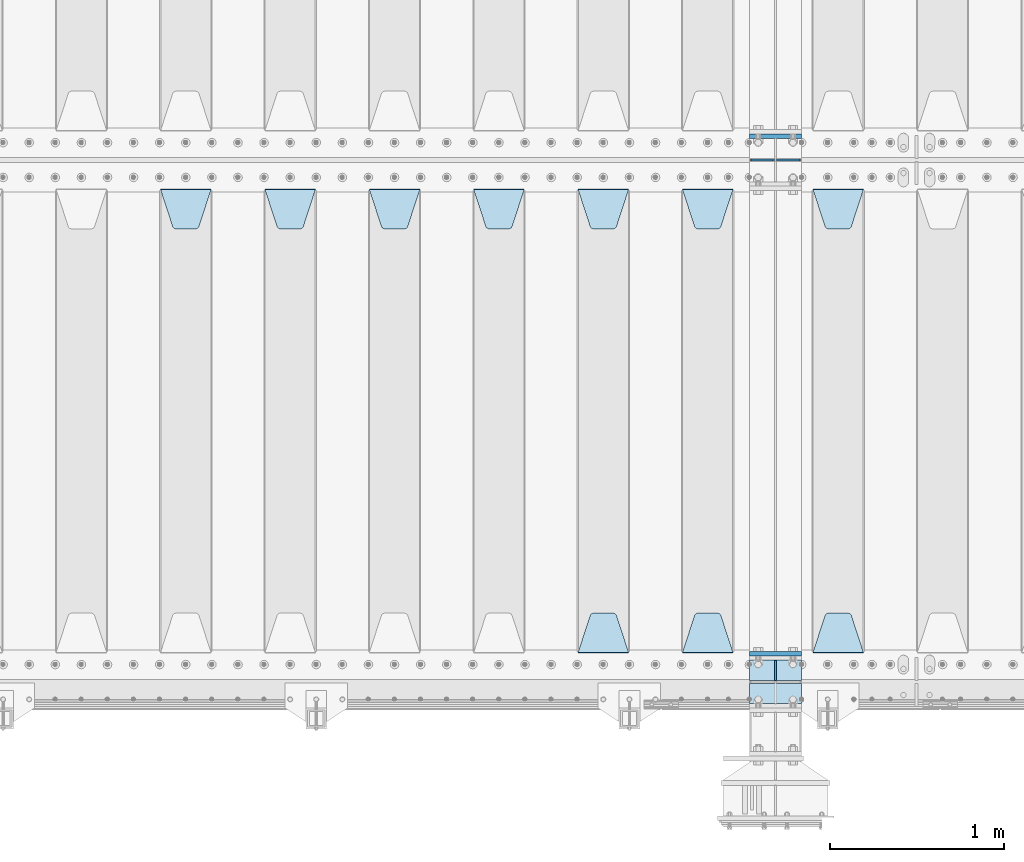
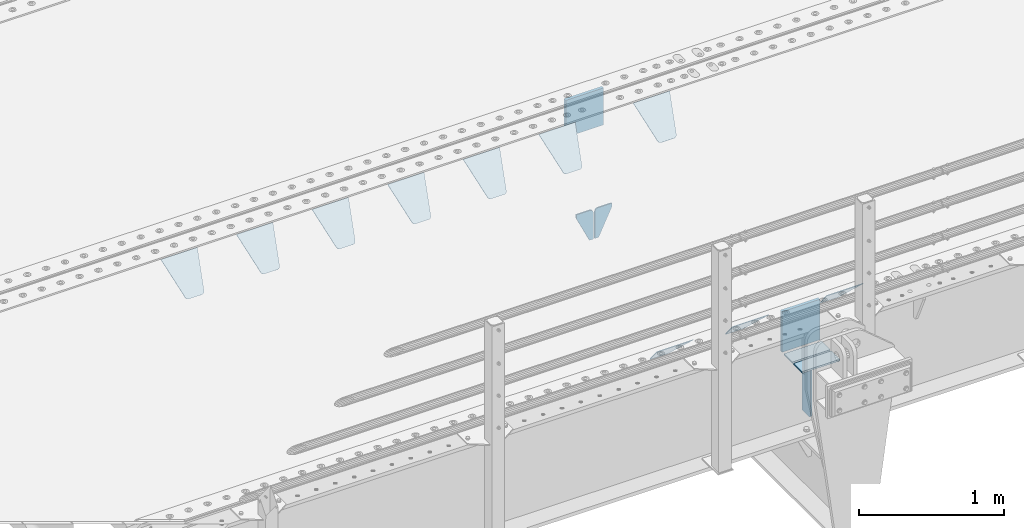
# One storey, part 183 of 219: 17 plates.
"""IFC2X3 building model written with IfcOpenShell, lengths in millimetres."""

import ifcopenshell
import ifcopenshell.guid

model = None  # the IFC model being written
_history = None  # IfcOwnerHistory: only IFC2X3 demands one
_inside = {}  # id of a spatial element -> (the spatial element, [elements in it])
_under = {}  # id of a project, library or spatial element -> (it, [spatial elements below it])
_declared = {}  # id of a project -> (the project, [libraries it declares])
_typed = {}  # id of a type object -> (the type object, [elements of that type])
_made_of = {}  # id of a material, layer set ... -> (it, [elements and type objects made of it])


def new_model(schema):
    """Start an empty IFC model of exactly this schema.

    Asked for "IFC4X3", IfcOpenShell would pick the latest addendum, in which some entities
    have other attributes; the version numbers below select the first issue.
    IFC2X3 requires an IfcOwnerHistory on every rooted entity: one is made here for all.
    """
    global model, _history
    if schema == "IFC4X3":
        model = ifcopenshell.file(schema_version=(4, 3, 0, 0))
    else:
        model = ifcopenshell.file(schema=schema)
    _inside.clear()
    _under.clear()
    _declared.clear()
    _typed.clear()
    _made_of.clear()
    _history = None
    if model.schema == "IFC2X3":
        org = make("IfcOrganization", Name="unknown")
        user = make(
            "IfcPersonAndOrganization",
            ThePerson=make("IfcPerson", FamilyName="unknown"),
            TheOrganization=org,
        )
        app = make(
            "IfcApplication",
            ApplicationDeveloper=org,
            Version="unknown",
            ApplicationFullName="unknown",
            ApplicationIdentifier="unknown",
        )
        _history = make(
            "IfcOwnerHistory",
            OwningUser=user,
            OwningApplication=app,
            ChangeAction="ADDED",
            CreationDate=0,
        )
    return model


def make(cls, **values):
    """One entity of the class cls with the attributes given. An attribute that is None is left unset."""
    return model.create_entity(
        cls, **{name: value for name, value in values.items() if value is not None}
    )


def rooted(cls, **values):
    """An entity with a GlobalId (a new one), such as an element, a storey or a relation."""
    return make(cls, GlobalId=ifcopenshell.guid.new(), OwnerHistory=_history, **values)


def si_unit(unit_type, name, prefix=None):
    """IfcSIUnit, for example si_unit("LENGTHUNIT", "METRE", prefix="MILLI")."""
    return make("IfcSIUnit", UnitType=unit_type, Prefix=prefix, Name=name)


def assignment(units):
    """IfcUnitAssignment: the units of a project."""
    return None if units is None else make("IfcUnitAssignment", Units=units)


def point(xyz):
    """IfcCartesianPoint."""
    return None if xyz is None else make("IfcCartesianPoint", Coordinates=xyz)


def direction(xyz):
    """IfcDirection."""
    return None if xyz is None else make("IfcDirection", DirectionRatios=xyz)


def frame(location, z_axis=None, x_axis=None):
    """IfcAxis2Placement3D, a coordinate frame: its origin and axes. An axis left out is left unset."""
    return make(
        "IfcAxis2Placement3D",
        Location=point(location),
        Axis=direction(z_axis),
        RefDirection=direction(x_axis),
    )


def origin_with_axes():
    """The frame at (0, 0, 0) with the z axis (0, 0, 1) and the x axis (1, 0, 0) written out."""
    return frame((0.0, 0.0, 0.0), z_axis=(0.0, 0.0, 1.0), x_axis=(1.0, 0.0, 0.0))


def place(relative_to, where):
    """IfcLocalPlacement: puts the frame where relative to a parent placement (None: the world)."""
    return make(
        "IfcLocalPlacement", PlacementRelTo=relative_to, RelativePlacement=where
    )


def context(
    kind, dimensions, precision=None, world=None, true_north=None, identifier=None
):
    """IfcGeometricRepresentationContext, for example the 3D "Model" context."""
    return make(
        "IfcGeometricRepresentationContext",
        ContextIdentifier=identifier,
        ContextType=kind,
        CoordinateSpaceDimension=dimensions,
        Precision=precision,
        WorldCoordinateSystem=world,
        TrueNorth=true_north,
    )


def subcontext(parent, identifier, kind, view, scale=None):
    """IfcGeometricRepresentationSubContext, for example "Body" below "Model"."""
    return make(
        "IfcGeometricRepresentationSubContext",
        ContextIdentifier=identifier,
        ContextType=kind,
        ParentContext=parent,
        TargetScale=scale,
        TargetView=view,
    )


def project(units=None, contexts=None):
    """IfcProject with its units and contexts."""
    return rooted(
        "IfcProject",
        Name="project",
        RepresentationContexts=contexts,
        UnitsInContext=assignment(units),
    )


def spatial(cls, under=None, at=None, **own):
    """A site, building, storey or space (cls), placed at a placement, below another one or the project."""
    s = rooted(cls, ObjectPlacement=at, **own)
    if under is not None:
        _under.setdefault(under.id(), (under, []))[1].append(s)
    return s


def faces_of(points, faces, orient=None, outer=None):
    """IfcFace entities. A face is a list of loops; a loop is a list of indices into points, from 0.

    orient and outer hold one flag for each loop. By default every Orientation is true, the
    first loop of a face is its IfcFaceOuterBound and the others are IfcFaceBound.
    """
    made = []
    for i, loops in enumerate(faces):
        bounds = []
        for j, loop in enumerate(loops):
            is_outer = j == 0 if outer is None else outer[i][j]
            bounds.append(
                make(
                    "IfcFaceOuterBound" if is_outer else "IfcFaceBound",
                    Bound=make("IfcPolyLoop", Polygon=[points[k] for k in loop]),
                    Orientation=True if orient is None else orient[i][j],
                )
            )
        made.append(make("IfcFace", Bounds=bounds))
    return made


def faceted_brep(points, faces, orient=None, outer=None, voids=None):
    """IfcFacetedBrep: a solid bounded by flat faces; with voids (closed shells), ...WithVoids."""
    shared = [point(p) for p in points]
    hull = make("IfcClosedShell", CfsFaces=faces_of(shared, faces, orient, outer))
    if voids is None:
        return make("IfcFacetedBrep", Outer=hull)
    return make(
        "IfcFacetedBrepWithVoids",
        Outer=hull,
        Voids=[
            make(cls, CfsFaces=faces_of(shared, fs, o, b)) for cls, fs, o, b in voids
        ],
    )


def shape(context_of_items, identifier, shape_type, items):
    """IfcShapeRepresentation: the items that make up one representation, for example the "Body"."""
    return make(
        "IfcShapeRepresentation",
        ContextOfItems=context_of_items,
        RepresentationIdentifier=identifier,
        RepresentationType=shape_type,
        Items=items,
    )


def material(Name=None, Category=None):
    """IfcMaterial."""
    return make("IfcMaterial", Name=Name, Category=Category)


def made_of(thing, what):
    """Note that an element or type object is made of a material, layer set ...; save() writes the relation."""
    if what is not None:
        _made_of.setdefault(what.id(), (what, []))[1].append(thing)
    return thing


def type_object(cls, material=None, **own):
    """A type object (cls), such as IfcWallType, which elements share."""
    return made_of(rooted(cls, **own), material)


def element(
    cls,
    number,
    at=None,
    inside=None,
    cuts=None,
    type_object=None,
    material=None,
    context=None,
    identifier="Body",
    shape_type=None,
    held_by="IfcProductDefinitionShape",
    body=None,
    shapes=None,
    **own,
):
    """One element of the class cls, such as IfcWall. Its Tag is "e" and its number.

    at: its placement. inside: the storey or other place that contains it. cuts: it is an
    opening in that element (IfcRelVoidsElement). A single representation is given by context,
    identifier, shape_type and body (its items); several are given by shapes. held_by: the class
    of the entity that holds the representations. save() writes the other relations.
    """
    e = rooted(cls, Tag="e%d" % number, ObjectPlacement=at, **own)
    if body is not None:
        shapes = [shape(context, identifier, shape_type, body)]
    if shapes is not None:
        e.Representation = make(held_by, Representations=shapes)
    if inside is not None:
        _inside.setdefault(inside.id(), (inside, []))[1].append(e)
    if cuts is not None:
        rooted(
            "IfcRelVoidsElement", RelatingBuildingElement=cuts, RelatedOpeningElement=e
        )
    if type_object is not None:
        _typed.setdefault(type_object.id(), (type_object, []))[1].append(e)
    return made_of(e, material)


def aggregate(whole, parts):
    """IfcRelAggregates: a whole, such as a stair, and the parts it consists of."""
    return rooted("IfcRelAggregates", RelatingObject=whole, RelatedObjects=parts)


def save(model, path):
    """Write the relations noted so far, then the file.

    IfcRelAggregates (storeys below a building ...), IfcRelContainedInSpatialStructure (elements
    in a storey), IfcRelDefinesByType, IfcRelAssociatesMaterial and IfcRelDeclares: one each for
    every whole, place, type object, material and project.
    """
    for whole, parts in _under.values():
        aggregate(whole, parts)
    for where, things in _inside.values():
        rooted(
            "IfcRelContainedInSpatialStructure",
            RelatedElements=things,
            RelatingStructure=where,
        )
    for kind, things in _typed.values():
        rooted("IfcRelDefinesByType", RelatedObjects=things, RelatingType=kind)
    for what, things in _made_of.values():
        rooted("IfcRelAssociatesMaterial", RelatedObjects=things, RelatingMaterial=what)
    for by, libraries in _declared.values():
        rooted("IfcRelDeclares", RelatingContext=by, RelatedDefinitions=libraries)
    model.write(path)


model = new_model("IFC2X3")

# Units and contexts
model_context = context("Model", 3, precision=1e-05, world=origin_with_axes())
body_context = subcontext(model_context, "Body", "Model", "MODEL_VIEW")
ifc_project = project(units=[si_unit("LENGTHUNIT", "METRE", prefix="MILLI"), si_unit("AREAUNIT", "SQUARE_METRE"), si_unit("VOLUMEUNIT", "CUBIC_METRE"), si_unit("MASSUNIT", "GRAM", prefix="KILO"), si_unit("TIMEUNIT", "SECOND"), si_unit("PLANEANGLEUNIT", "RADIAN"), si_unit("SOLIDANGLEUNIT", "STERADIAN"), si_unit("THERMODYNAMICTEMPERATUREUNIT", "DEGREE_CELSIUS"), si_unit("LUMINOUSINTENSITYUNIT", "LUMEN")], contexts=[model_context])

# Site, building, storey
site_placement = place(None, origin_with_axes())
site = spatial("IfcSite", under=ifc_project, at=site_placement, CompositionType="ELEMENT")
building_placement = place(site_placement, origin_with_axes())
building = spatial("IfcBuilding", under=site, at=building_placement, Name="Standard", CompositionType="ELEMENT")
storey_placement = place(building_placement, origin_with_axes())
storey = spatial("IfcBuildingStorey", under=building, at=storey_placement, Name="Undefined", CompositionType="ELEMENT", Elevation=0.0)

# Plates
ifc_material = material(Name="STEEL/S355N")
plate_type_1 = type_object("IfcPlateType", PredefinedType="NOTDEFINED")
plate_1_placement = place(storey_placement, frame((10240.0, 27137.5, -340.0), z_axis=(0.0, 0.0, 1.0), x_axis=(1.0, 0.0, 0.0)))
element("IfcPlate", 1, at=plate_1_placement, inside=storey, type_object=plate_type_1, material=ifc_material, context=body_context, shape_type="Brep", body=[
    faceted_brep([(0.0, -12.5, 0.0), (0.0, -12.5, 310.0), (0.0, 12.5, 310.0), (0.0, 12.5, 0.0), (300.0, -12.5, 310.0), (300.0, 12.5, 310.0), (300.0, -12.5, 0.0), (300.0, 12.5, 0.0)], [[[0, 1, 2, 3]], [[1, 4, 5, 2]], [[4, 6, 7, 5]], [[6, 0, 3, 7]], [[5, 7, 3, 2]], [[6, 4, 1, 0]]]),
])
plate_2_placement = place(storey_placement, frame((10240.0, 24162.5, -340.000000000044), z_axis=(0.0, 0.0, 1.0), x_axis=(1.0, 0.0, 0.0)))
element("IfcPlate", 2, at=plate_2_placement, inside=storey, type_object=plate_type_1, material=ifc_material, context=body_context, shape_type="Brep", body=[
    faceted_brep([(0.0, -12.5, 0.0), (9.27684595808387e-10, -12.5, 340.0), (9.27684595808387e-10, 12.5, 340.0), (0.0, 12.5, 0.0), (300.0, -12.5, 340.0), (300.0, 12.5, 340.0), (300.0, -12.5, 0.0), (300.0, 12.5, 0.0)], [[[0, 1, 2, 3]], [[1, 4, 5, 2]], [[4, 6, 7, 5]], [[6, 0, 3, 7]], [[5, 7, 3, 2]], [[6, 4, 1, 0]]]),
])
plate_type_2 = type_object("IfcPlateType", PredefinedType="NOTDEFINED")
for number, where, z_axis, x_axis in (
    (3, (10240.0, 23992.0, -343.0), (0.0, -1.0, 0.0), (1.0, 0.0, 0.0)),
    (4, (10240.0, 24008.0, -343.0), (0.0, 1.0, 0.0), (1.0, 0.0, 0.0)),
):
    element("IfcPlate", number, at=place(storey_placement, frame(where, z_axis=z_axis, x_axis=x_axis)), inside=storey, type_object=plate_type_2, material=ifc_material, context=body_context, shape_type="Brep", body=[
        faceted_brep([(0.0, -7.0, 0.0), (0.0, -7.0, 117.0), (0.0, 7.0, 117.0), (0.0, 7.0, 0.0), (300.0, -7.0, 117.0), (300.0, 7.0, 117.0), (300.0, -7.0, 0.0), (300.0, 7.0, 0.0)], [[[0, 1, 2, 3]], [[1, 4, 5, 2]], [[4, 6, 7, 5]], [[6, 0, 3, 7]], [[5, 7, 3, 2]], [[6, 4, 1, 0]]]),
    ])
plate_type_3 = type_object("IfcPlateType", PredefinedType="NOTDEFINED")
plate_3_placement = place(storey_placement, frame((10390.0, 24008.0, -350.0), z_axis=(0.0, 0.0, -1.0), x_axis=(0.0, 1.0, 0.0)))
element("IfcPlate", 5, at=plate_3_placement, inside=storey, type_object=plate_type_3, material=ifc_material, context=body_context, shape_type="Brep", body=[
    faceted_brep([(0.0, -5.0, 0.0), (0.0, -5.0, 480.0), (0.0, 5.0, 480.0), (0.0, 5.0, 0.0), (0.455767409635882, -5.0, 485.209445330008), (0.455767409635882, 5.0, 485.209445330008), (1.80922137642483, -5.0, 490.26060429977), (1.80922137642483, 5.0, 490.26060429977), (4.01923788646673, -5.0, 495.0), (4.01923788646673, 5.0, 495.0), (7.01866670643358, -5.0, 499.283628290596), (7.01866670643358, 5.0, 499.283628290596), (10.7163717094008, -5.0, 502.981333293569), (10.7163717094008, 5.0, 502.981333293569), (15.0, -5.0, 505.980762113533), (15.0, 5.0, 505.980762113533), (19.7393957002278, -5.0, 508.190778623577), (19.7393957002278, 5.0, 508.190778623577), (24.7905546699913, -5.0, 509.544232590366), (24.7905546699913, 5.0, 509.544232590366), (30.0, -5.0, 510.0), (30.0, 5.0, 510.0), (117.0, -5.0, 510.0), (117.0, 5.0, 510.0), (117.0, -5.0, 0.0), (117.0, 5.0, 0.0)], [[[0, 1, 2, 3]], [[1, 4, 5, 2]], [[4, 6, 7, 5]], [[6, 8, 9, 7]], [[8, 10, 11, 9]], [[10, 12, 13, 11]], [[12, 14, 15, 13]], [[14, 16, 17, 15]], [[16, 18, 19, 17]], [[18, 20, 21, 19]], [[20, 22, 23, 21]], [[22, 24, 25, 23]], [[24, 0, 3, 25]], [[5, 7, 9, 11, 13, 15, 17, 19, 21, 23, 25, 3, 2]], [[24, 22, 20, 18, 16, 14, 12, 10, 8, 6, 4, 1, 0]]]),
])
plate_type_4 = type_object("IfcPlateType", PredefinedType="NOTDEFINED")
for number, where, z_axis, x_axis in (
    (6, (10383.5000000198, 27000.0000000149, -915.000018206196), (0.0, 0.0, -1.0), (-1.0, 0.0, 0.0)),
    (7, (10396.5000000199, 27000.0000000149, -915.000018206196), (0.0, 0.0, -1.0), (1.0, 0.0, 0.0)),
):
    element("IfcPlate", number, at=place(storey_placement, frame(where, z_axis=z_axis, x_axis=x_axis)), inside=storey, type_object=plate_type_4, material=ifc_material, context=body_context, shape_type="Brep", body=[
        faceted_brep([(0.0, -5.0, 27.0), (0.0, -5.0, 250.0), (0.0, 5.0, 250.0), (0.0, 5.0, 27.0), (30.0, -5.0, 250.0), (30.0, 5.0, 250.0), (135.0, -5.0, 30.0), (135.0, 5.0, 30.0), (135.0, -5.0, 0.0), (135.0, 5.0, 0.0), (27.0, -5.0, 0.0), (27.0, 5.0, 0.0), (22.3114992029932, -5.0, 0.410190668670339), (22.3114992029932, 5.0, 0.410190668670339), (17.7654561302061, -5.0, 1.62829923878041), (17.7654561302061, 5.0, 1.62829923878041), (13.5, -5.0, 3.61731409782021), (13.5, 5.0, 3.61731409782021), (9.64473453846404, -5.0, 6.31680003578765), (9.64473453846404, 5.0, 6.31680003578765), (6.31680003578731, -5.0, 9.64473453846347), (6.31680003578731, 5.0, 9.64473453846347), (3.61731409782078, -5.0, 13.5), (3.61731409782078, 5.0, 13.5), (1.62829923878053, -5.0, 17.765456130207), (1.62829923878053, 5.0, 17.765456130207), (0.410190668670111, -5.0, 22.3114992029929), (0.410190668670111, 5.0, 22.3114992029929)], [[[0, 1, 2, 3]], [[1, 4, 5, 2]], [[4, 6, 7, 5]], [[6, 8, 9, 7]], [[8, 10, 11, 9]], [[10, 12, 13, 11]], [[12, 14, 15, 13]], [[14, 16, 17, 15]], [[16, 18, 19, 17]], [[18, 20, 21, 19]], [[20, 22, 23, 21]], [[22, 24, 25, 23]], [[24, 26, 27, 25]], [[26, 0, 3, 27]], [[5, 7, 9, 11, 13, 15, 17, 19, 21, 23, 25, 27, 3, 2]], [[26, 24, 22, 20, 18, 16, 14, 12, 10, 8, 6, 4, 1, 0]]]),
    ])
plate_type_5 = type_object("IfcPlateType", PredefinedType="NOTDEFINED")
plate_4_placement = place(storey_placement, frame((10605.0, 26831.767766956, -1.76776695296758), z_axis=(0.0, -0.707106781186547, -0.707106781186548), x_axis=(1.0, 0.0, 0.0)))
element("IfcPlate", 8, at=plate_4_placement, inside=storey, type_object=plate_type_5, material=ifc_material, context=body_context, shape_type="Brep", body=[
    faceted_brep([(0.0, -2.5, 0.0), (69.345504679477, -2.5, 300.171731424834), (69.345504679477, 2.49999999999636, 300.171731424831), (0.0, 2.5, 0.0), (70.9274061199576, -2.50000000000364, 304.8974424154), (70.9274061199576, 2.49999999999636, 304.8974424154), (73.3818627772307, -2.50000000000364, 309.234538108532), (73.3818627772307, 2.49999999999636, 309.234538108532), (76.6187032999569, -2.50000000000364, 313.023683126106), (76.6187032999569, 2.49999999999636, 313.023683126106), (80.5190132704993, -2.50000000000364, 316.125672595372), (80.5190132704993, 2.49999999999636, 316.125672595372), (84.9395038596831, -2.50000000000364, 318.426546230476), (84.9395038596831, 2.5, 318.426546230479), (89.7177759439237, -2.50000000000364, 319.841774983277), (89.7177759439237, 2.5, 319.841774983281), (94.6782862926502, -2.50000000000364, 320.319366455078), (94.6782862926502, 2.49999999999636, 320.319366455078), (195.32171370735, -2.50000000000364, 320.319366455078), (195.32171370735, 2.49999999999636, 320.319366455078), (200.282224056076, -2.50000000000364, 319.841774983277), (200.282224056076, 2.5, 319.841774983281), (205.060496140317, -2.50000000000364, 318.426546230476), (205.060496140317, 2.49999999999636, 318.426546230476), (209.480986729501, -2.50000000000364, 316.125672595372), (209.480986729501, 2.49999999999636, 316.125672595372), (213.381296700043, -2.50000000000364, 313.023683126106), (213.381296700043, 2.49999999999272, 313.023683126106), (216.618137222769, -2.50000000000364, 309.234538108529), (216.618137222769, 2.49999999999636, 309.234538108525), (219.072593880042, -2.50000000000364, 304.8974424154), (219.072593880042, 2.49999999999636, 304.8974424154), (220.654495320523, -2.5, 300.171731424834), (220.654495320523, 2.49999999999636, 300.171731424831), (290.0, -2.50000000000364, 3.63797880709171e-12), (290.0, 2.49999999999636, 0.0)], [[[0, 1, 2, 3]], [[1, 4, 5, 2]], [[4, 6, 7, 5]], [[6, 8, 9, 7]], [[8, 10, 11, 9]], [[10, 12, 13, 11]], [[12, 14, 15, 13]], [[14, 16, 17, 15]], [[16, 18, 19, 17]], [[18, 20, 21, 19]], [[20, 22, 23, 21]], [[22, 24, 25, 23]], [[24, 26, 27, 25]], [[26, 28, 29, 27]], [[28, 30, 31, 29]], [[30, 32, 33, 31]], [[32, 34, 35, 33]], [[34, 0, 3, 35]], [[5, 7, 9, 11, 13, 15, 17, 19, 21, 23, 25, 27, 29, 31, 33, 35, 3, 2]], [[34, 32, 30, 28, 26, 24, 22, 20, 18, 16, 14, 12, 10, 8, 6, 4, 1, 0]]]),
])
plate_5_placement = place(storey_placement, frame((10895.0, 24168.232233047, -1.76776695296758), z_axis=(0.0, 0.707106781186547, -0.707106781186548), x_axis=(-1.0, 0.0, 0.0)))
element("IfcPlate", 9, at=plate_5_placement, inside=storey, type_object=plate_type_5, material=ifc_material, context=body_context, shape_type="Brep", body=[
    faceted_brep([(0.0, -2.5, 0.0), (69.345504679477, -2.5, 300.171731424834), (69.345504679477, 2.49999999999636, 300.171731424831), (0.0, 2.5, 0.0), (70.9274061199576, -2.50000000000364, 304.8974424154), (70.9274061199576, 2.49999999999636, 304.8974424154), (73.3818627772307, -2.50000000000364, 309.234538108532), (73.3818627772307, 2.49999999999636, 309.234538108532), (76.6187032999569, -2.50000000000364, 313.023683126106), (76.6187032999569, 2.49999999999636, 313.023683126106), (80.5190132704993, -2.50000000000364, 316.125672595372), (80.5190132704993, 2.49999999999636, 316.125672595372), (84.9395038596831, -2.50000000000364, 318.426546230476), (84.9395038596831, 2.5, 318.426546230479), (89.7177759439237, -2.50000000000364, 319.841774983277), (89.7177759439237, 2.5, 319.841774983281), (94.6782862926502, -2.50000000000364, 320.319366455078), (94.6782862926502, 2.49999999999636, 320.319366455078), (195.32171370735, -2.50000000000364, 320.319366455078), (195.32171370735, 2.49999999999636, 320.319366455078), (200.282224056076, -2.50000000000364, 319.841774983277), (200.282224056076, 2.5, 319.841774983281), (205.060496140317, -2.50000000000364, 318.426546230476), (205.060496140317, 2.49999999999636, 318.426546230476), (209.480986729501, -2.50000000000364, 316.125672595372), (209.480986729501, 2.49999999999636, 316.125672595372), (213.381296700043, -2.50000000000364, 313.023683126106), (213.381296700043, 2.49999999999272, 313.023683126106), (216.618137222769, -2.50000000000364, 309.234538108529), (216.618137222769, 2.49999999999636, 309.234538108525), (219.072593880042, -2.50000000000364, 304.8974424154), (219.072593880042, 2.49999999999636, 304.8974424154), (220.654495320523, -2.5, 300.171731424834), (220.654495320523, 2.49999999999636, 300.171731424831), (290.0, -2.50000000000364, 3.63797880709171e-12), (290.0, 2.49999999999636, 0.0)], [[[0, 1, 2, 3]], [[1, 4, 5, 2]], [[4, 6, 7, 5]], [[6, 8, 9, 7]], [[8, 10, 11, 9]], [[10, 12, 13, 11]], [[12, 14, 15, 13]], [[14, 16, 17, 15]], [[16, 18, 19, 17]], [[18, 20, 21, 19]], [[20, 22, 23, 21]], [[22, 24, 25, 23]], [[24, 26, 27, 25]], [[26, 28, 29, 27]], [[28, 30, 31, 29]], [[30, 32, 33, 31]], [[32, 34, 35, 33]], [[34, 0, 3, 35]], [[5, 7, 9, 11, 13, 15, 17, 19, 21, 23, 25, 27, 29, 31, 33, 35, 3, 2]], [[34, 32, 30, 28, 26, 24, 22, 20, 18, 16, 14, 12, 10, 8, 6, 4, 1, 0]]]),
])
plate_6_placement = place(storey_placement, frame((9855.0, 26831.767766956, -1.76776695296758), z_axis=(0.0, -0.707106781186547, -0.707106781186548), x_axis=(1.0, 0.0, 0.0)))
element("IfcPlate", 10, at=plate_6_placement, inside=storey, type_object=plate_type_5, material=ifc_material, context=body_context, shape_type="Brep", body=[
    faceted_brep([(0.0, -2.5, 0.0), (69.345504679477, -2.5, 300.171731424834), (69.345504679477, 2.49999999999636, 300.171731424831), (0.0, 2.5, 0.0), (70.9274061199576, -2.50000000000364, 304.8974424154), (70.9274061199576, 2.49999999999636, 304.8974424154), (73.3818627772307, -2.50000000000364, 309.234538108532), (73.3818627772307, 2.49999999999636, 309.234538108532), (76.6187032999569, -2.50000000000364, 313.023683126106), (76.6187032999569, 2.49999999999636, 313.023683126106), (80.5190132704993, -2.50000000000364, 316.125672595372), (80.5190132704993, 2.49999999999636, 316.125672595372), (84.9395038596831, -2.50000000000364, 318.426546230476), (84.9395038596831, 2.5, 318.426546230479), (89.7177759439237, -2.50000000000364, 319.841774983277), (89.7177759439237, 2.5, 319.841774983281), (94.6782862926502, -2.50000000000364, 320.319366455078), (94.6782862926502, 2.49999999999636, 320.319366455078), (195.32171370735, -2.50000000000364, 320.319366455078), (195.32171370735, 2.49999999999636, 320.319366455078), (200.282224056076, -2.50000000000364, 319.841774983277), (200.282224056076, 2.5, 319.841774983281), (205.060496140317, -2.50000000000364, 318.426546230476), (205.060496140317, 2.49999999999636, 318.426546230476), (209.480986729501, -2.50000000000364, 316.125672595372), (209.480986729501, 2.49999999999636, 316.125672595372), (213.381296700043, -2.50000000000364, 313.023683126106), (213.381296700043, 2.49999999999272, 313.023683126106), (216.618137222769, -2.50000000000364, 309.234538108529), (216.618137222769, 2.49999999999636, 309.234538108525), (219.072593880042, -2.50000000000364, 304.8974424154), (219.072593880042, 2.49999999999636, 304.8974424154), (220.654495320523, -2.5, 300.171731424834), (220.654495320523, 2.49999999999636, 300.171731424831), (290.0, -2.50000000000364, 3.63797880709171e-12), (290.0, 2.49999999999636, 0.0)], [[[0, 1, 2, 3]], [[1, 4, 5, 2]], [[4, 6, 7, 5]], [[6, 8, 9, 7]], [[8, 10, 11, 9]], [[10, 12, 13, 11]], [[12, 14, 15, 13]], [[14, 16, 17, 15]], [[16, 18, 19, 17]], [[18, 20, 21, 19]], [[20, 22, 23, 21]], [[22, 24, 25, 23]], [[24, 26, 27, 25]], [[26, 28, 29, 27]], [[28, 30, 31, 29]], [[30, 32, 33, 31]], [[32, 34, 35, 33]], [[34, 0, 3, 35]], [[5, 7, 9, 11, 13, 15, 17, 19, 21, 23, 25, 27, 29, 31, 33, 35, 3, 2]], [[34, 32, 30, 28, 26, 24, 22, 20, 18, 16, 14, 12, 10, 8, 6, 4, 1, 0]]]),
])
plate_7_placement = place(storey_placement, frame((10145.0, 24168.232233047, -1.76776695296758), z_axis=(0.0, 0.707106781186547, -0.707106781186548), x_axis=(-1.0, 0.0, 0.0)))
element("IfcPlate", 11, at=plate_7_placement, inside=storey, type_object=plate_type_5, material=ifc_material, context=body_context, shape_type="Brep", body=[
    faceted_brep([(0.0, -2.5, 0.0), (69.345504679477, -2.5, 300.171731424834), (69.345504679477, 2.49999999999636, 300.171731424831), (0.0, 2.5, 0.0), (70.9274061199576, -2.50000000000364, 304.8974424154), (70.9274061199576, 2.49999999999636, 304.8974424154), (73.3818627772307, -2.50000000000364, 309.234538108532), (73.3818627772307, 2.49999999999636, 309.234538108532), (76.6187032999569, -2.50000000000364, 313.023683126106), (76.6187032999569, 2.49999999999636, 313.023683126106), (80.5190132704993, -2.50000000000364, 316.125672595372), (80.5190132704993, 2.49999999999636, 316.125672595372), (84.9395038596831, -2.50000000000364, 318.426546230476), (84.9395038596831, 2.5, 318.426546230479), (89.7177759439237, -2.50000000000364, 319.841774983277), (89.7177759439237, 2.5, 319.841774983281), (94.6782862926502, -2.50000000000364, 320.319366455078), (94.6782862926502, 2.49999999999636, 320.319366455078), (195.32171370735, -2.50000000000364, 320.319366455078), (195.32171370735, 2.49999999999636, 320.319366455078), (200.282224056076, -2.50000000000364, 319.841774983277), (200.282224056076, 2.5, 319.841774983281), (205.060496140317, -2.50000000000364, 318.426546230476), (205.060496140317, 2.49999999999636, 318.426546230476), (209.480986729501, -2.50000000000364, 316.125672595372), (209.480986729501, 2.49999999999636, 316.125672595372), (213.381296700043, -2.50000000000364, 313.023683126106), (213.381296700043, 2.49999999999272, 313.023683126106), (216.618137222769, -2.50000000000364, 309.234538108529), (216.618137222769, 2.49999999999636, 309.234538108525), (219.072593880042, -2.50000000000364, 304.8974424154), (219.072593880042, 2.49999999999636, 304.8974424154), (220.654495320523, -2.5, 300.171731424834), (220.654495320523, 2.49999999999636, 300.171731424831), (290.0, -2.50000000000364, 3.63797880709171e-12), (290.0, 2.49999999999636, 0.0)], [[[0, 1, 2, 3]], [[1, 4, 5, 2]], [[4, 6, 7, 5]], [[6, 8, 9, 7]], [[8, 10, 11, 9]], [[10, 12, 13, 11]], [[12, 14, 15, 13]], [[14, 16, 17, 15]], [[16, 18, 19, 17]], [[18, 20, 21, 19]], [[20, 22, 23, 21]], [[22, 24, 25, 23]], [[24, 26, 27, 25]], [[26, 28, 29, 27]], [[28, 30, 31, 29]], [[30, 32, 33, 31]], [[32, 34, 35, 33]], [[34, 0, 3, 35]], [[5, 7, 9, 11, 13, 15, 17, 19, 21, 23, 25, 27, 29, 31, 33, 35, 3, 2]], [[34, 32, 30, 28, 26, 24, 22, 20, 18, 16, 14, 12, 10, 8, 6, 4, 1, 0]]]),
])
plate_8_placement = place(storey_placement, frame((9255.0, 26831.767766956, -1.76776695296758), z_axis=(0.0, -0.707106781186547, -0.707106781186548), x_axis=(1.0, 0.0, 0.0)))
element("IfcPlate", 12, at=plate_8_placement, inside=storey, type_object=plate_type_5, material=ifc_material, context=body_context, shape_type="Brep", body=[
    faceted_brep([(0.0, -2.5, 0.0), (69.345504679477, -2.5, 300.171731424834), (69.345504679477, 2.49999999999636, 300.171731424831), (0.0, 2.5, 0.0), (70.9274061199576, -2.50000000000364, 304.8974424154), (70.9274061199576, 2.49999999999636, 304.8974424154), (73.3818627772307, -2.50000000000364, 309.234538108532), (73.3818627772307, 2.49999999999636, 309.234538108532), (76.6187032999569, -2.50000000000364, 313.023683126106), (76.6187032999569, 2.49999999999636, 313.023683126106), (80.5190132704993, -2.50000000000364, 316.125672595372), (80.5190132704993, 2.49999999999636, 316.125672595372), (84.9395038596831, -2.50000000000364, 318.426546230476), (84.9395038596831, 2.5, 318.426546230479), (89.7177759439237, -2.50000000000364, 319.841774983277), (89.7177759439237, 2.5, 319.841774983281), (94.6782862926502, -2.50000000000364, 320.319366455078), (94.6782862926502, 2.49999999999636, 320.319366455078), (195.32171370735, -2.50000000000364, 320.319366455078), (195.32171370735, 2.49999999999636, 320.319366455078), (200.282224056076, -2.50000000000364, 319.841774983277), (200.282224056076, 2.5, 319.841774983281), (205.060496140317, -2.50000000000364, 318.426546230476), (205.060496140317, 2.49999999999636, 318.426546230476), (209.480986729501, -2.50000000000364, 316.125672595372), (209.480986729501, 2.49999999999636, 316.125672595372), (213.381296700043, -2.50000000000364, 313.023683126106), (213.381296700043, 2.49999999999272, 313.023683126106), (216.618137222769, -2.50000000000364, 309.234538108529), (216.618137222769, 2.49999999999636, 309.234538108525), (219.072593880042, -2.50000000000364, 304.8974424154), (219.072593880042, 2.49999999999636, 304.8974424154), (220.654495320523, -2.5, 300.171731424834), (220.654495320523, 2.49999999999636, 300.171731424831), (290.0, -2.50000000000364, 3.63797880709171e-12), (290.0, 2.49999999999636, 0.0)], [[[0, 1, 2, 3]], [[1, 4, 5, 2]], [[4, 6, 7, 5]], [[6, 8, 9, 7]], [[8, 10, 11, 9]], [[10, 12, 13, 11]], [[12, 14, 15, 13]], [[14, 16, 17, 15]], [[16, 18, 19, 17]], [[18, 20, 21, 19]], [[20, 22, 23, 21]], [[22, 24, 25, 23]], [[24, 26, 27, 25]], [[26, 28, 29, 27]], [[28, 30, 31, 29]], [[30, 32, 33, 31]], [[32, 34, 35, 33]], [[34, 0, 3, 35]], [[5, 7, 9, 11, 13, 15, 17, 19, 21, 23, 25, 27, 29, 31, 33, 35, 3, 2]], [[34, 32, 30, 28, 26, 24, 22, 20, 18, 16, 14, 12, 10, 8, 6, 4, 1, 0]]]),
])
plate_9_placement = place(storey_placement, frame((9545.0, 24168.232233047, -1.76776695296758), z_axis=(0.0, 0.707106781186547, -0.707106781186548), x_axis=(-1.0, 0.0, 0.0)))
element("IfcPlate", 13, at=plate_9_placement, inside=storey, type_object=plate_type_5, material=ifc_material, context=body_context, shape_type="Brep", body=[
    faceted_brep([(0.0, -2.5, 0.0), (69.345504679477, -2.5, 300.171731424834), (69.345504679477, 2.49999999999636, 300.171731424831), (0.0, 2.5, 0.0), (70.9274061199576, -2.50000000000364, 304.8974424154), (70.9274061199576, 2.49999999999636, 304.8974424154), (73.3818627772307, -2.50000000000364, 309.234538108532), (73.3818627772307, 2.49999999999636, 309.234538108532), (76.6187032999569, -2.50000000000364, 313.023683126106), (76.6187032999569, 2.49999999999636, 313.023683126106), (80.5190132704993, -2.50000000000364, 316.125672595372), (80.5190132704993, 2.49999999999636, 316.125672595372), (84.9395038596831, -2.50000000000364, 318.426546230476), (84.9395038596831, 2.5, 318.426546230479), (89.7177759439237, -2.50000000000364, 319.841774983277), (89.7177759439237, 2.5, 319.841774983281), (94.6782862926502, -2.50000000000364, 320.319366455078), (94.6782862926502, 2.49999999999636, 320.319366455078), (195.32171370735, -2.50000000000364, 320.319366455078), (195.32171370735, 2.49999999999636, 320.319366455078), (200.282224056076, -2.50000000000364, 319.841774983277), (200.282224056076, 2.5, 319.841774983281), (205.060496140317, -2.50000000000364, 318.426546230476), (205.060496140317, 2.49999999999636, 318.426546230476), (209.480986729501, -2.50000000000364, 316.125672595372), (209.480986729501, 2.49999999999636, 316.125672595372), (213.381296700043, -2.50000000000364, 313.023683126106), (213.381296700043, 2.49999999999272, 313.023683126106), (216.618137222769, -2.50000000000364, 309.234538108529), (216.618137222769, 2.49999999999636, 309.234538108525), (219.072593880042, -2.50000000000364, 304.8974424154), (219.072593880042, 2.49999999999636, 304.8974424154), (220.654495320523, -2.5, 300.171731424834), (220.654495320523, 2.49999999999636, 300.171731424831), (290.0, -2.50000000000364, 3.63797880709171e-12), (290.0, 2.49999999999636, 0.0)], [[[0, 1, 2, 3]], [[1, 4, 5, 2]], [[4, 6, 7, 5]], [[6, 8, 9, 7]], [[8, 10, 11, 9]], [[10, 12, 13, 11]], [[12, 14, 15, 13]], [[14, 16, 17, 15]], [[16, 18, 19, 17]], [[18, 20, 21, 19]], [[20, 22, 23, 21]], [[22, 24, 25, 23]], [[24, 26, 27, 25]], [[26, 28, 29, 27]], [[28, 30, 31, 29]], [[30, 32, 33, 31]], [[32, 34, 35, 33]], [[34, 0, 3, 35]], [[5, 7, 9, 11, 13, 15, 17, 19, 21, 23, 25, 27, 29, 31, 33, 35, 3, 2]], [[34, 32, 30, 28, 26, 24, 22, 20, 18, 16, 14, 12, 10, 8, 6, 4, 1, 0]]]),
])
plate_10_placement = place(storey_placement, frame((8655.0, 26831.767766956, -1.76776695296758), z_axis=(0.0, -0.707106781186547, -0.707106781186548), x_axis=(1.0, 0.0, 0.0)))
element("IfcPlate", 14, at=plate_10_placement, inside=storey, type_object=plate_type_5, material=ifc_material, context=body_context, shape_type="Brep", body=[
    faceted_brep([(0.0, -2.5, 0.0), (69.345504679477, -2.5, 300.171731424834), (69.345504679477, 2.49999999999636, 300.171731424831), (0.0, 2.5, 0.0), (70.9274061199576, -2.50000000000364, 304.8974424154), (70.9274061199576, 2.49999999999636, 304.8974424154), (73.3818627772307, -2.50000000000364, 309.234538108532), (73.3818627772307, 2.49999999999636, 309.234538108532), (76.6187032999569, -2.50000000000364, 313.023683126106), (76.6187032999569, 2.49999999999636, 313.023683126106), (80.5190132704993, -2.50000000000364, 316.125672595372), (80.5190132704993, 2.49999999999636, 316.125672595372), (84.9395038596831, -2.50000000000364, 318.426546230476), (84.9395038596831, 2.5, 318.426546230479), (89.7177759439237, -2.50000000000364, 319.841774983277), (89.7177759439237, 2.5, 319.841774983281), (94.6782862926502, -2.50000000000364, 320.319366455078), (94.6782862926502, 2.49999999999636, 320.319366455078), (195.32171370735, -2.50000000000364, 320.319366455078), (195.32171370735, 2.49999999999636, 320.319366455078), (200.282224056076, -2.50000000000364, 319.841774983277), (200.282224056076, 2.5, 319.841774983281), (205.060496140317, -2.50000000000364, 318.426546230476), (205.060496140317, 2.49999999999636, 318.426546230476), (209.480986729501, -2.50000000000364, 316.125672595372), (209.480986729501, 2.49999999999636, 316.125672595372), (213.381296700043, -2.50000000000364, 313.023683126106), (213.381296700043, 2.49999999999272, 313.023683126106), (216.618137222769, -2.50000000000364, 309.234538108529), (216.618137222769, 2.49999999999636, 309.234538108525), (219.072593880042, -2.50000000000364, 304.8974424154), (219.072593880042, 2.49999999999636, 304.8974424154), (220.654495320523, -2.5, 300.171731424834), (220.654495320523, 2.49999999999636, 300.171731424831), (290.0, -2.50000000000364, 3.63797880709171e-12), (290.0, 2.49999999999636, 0.0)], [[[0, 1, 2, 3]], [[1, 4, 5, 2]], [[4, 6, 7, 5]], [[6, 8, 9, 7]], [[8, 10, 11, 9]], [[10, 12, 13, 11]], [[12, 14, 15, 13]], [[14, 16, 17, 15]], [[16, 18, 19, 17]], [[18, 20, 21, 19]], [[20, 22, 23, 21]], [[22, 24, 25, 23]], [[24, 26, 27, 25]], [[26, 28, 29, 27]], [[28, 30, 31, 29]], [[30, 32, 33, 31]], [[32, 34, 35, 33]], [[34, 0, 3, 35]], [[5, 7, 9, 11, 13, 15, 17, 19, 21, 23, 25, 27, 29, 31, 33, 35, 3, 2]], [[34, 32, 30, 28, 26, 24, 22, 20, 18, 16, 14, 12, 10, 8, 6, 4, 1, 0]]]),
])
plate_11_placement = place(storey_placement, frame((8055.0, 26831.767766956, -1.76776695296758), z_axis=(0.0, -0.707106781186547, -0.707106781186548), x_axis=(1.0, 0.0, 0.0)))
element("IfcPlate", 15, at=plate_11_placement, inside=storey, type_object=plate_type_5, material=ifc_material, context=body_context, shape_type="Brep", body=[
    faceted_brep([(0.0, -2.5, 0.0), (69.345504679477, -2.5, 300.171731424834), (69.345504679477, 2.49999999999636, 300.171731424831), (0.0, 2.5, 0.0), (70.9274061199576, -2.50000000000364, 304.8974424154), (70.9274061199576, 2.49999999999636, 304.8974424154), (73.3818627772307, -2.50000000000364, 309.234538108532), (73.3818627772307, 2.49999999999636, 309.234538108532), (76.6187032999569, -2.50000000000364, 313.023683126106), (76.6187032999569, 2.49999999999636, 313.023683126106), (80.5190132704993, -2.50000000000364, 316.125672595372), (80.5190132704993, 2.49999999999636, 316.125672595372), (84.9395038596831, -2.50000000000364, 318.426546230476), (84.9395038596831, 2.5, 318.426546230479), (89.7177759439237, -2.50000000000364, 319.841774983277), (89.7177759439237, 2.5, 319.841774983281), (94.6782862926502, -2.50000000000364, 320.319366455078), (94.6782862926502, 2.49999999999636, 320.319366455078), (195.32171370735, -2.50000000000364, 320.319366455078), (195.32171370735, 2.49999999999636, 320.319366455078), (200.282224056076, -2.50000000000364, 319.841774983277), (200.282224056076, 2.5, 319.841774983281), (205.060496140317, -2.50000000000364, 318.426546230476), (205.060496140317, 2.49999999999636, 318.426546230476), (209.480986729501, -2.50000000000364, 316.125672595372), (209.480986729501, 2.49999999999636, 316.125672595372), (213.381296700043, -2.50000000000364, 313.023683126106), (213.381296700043, 2.49999999999272, 313.023683126106), (216.618137222769, -2.50000000000364, 309.234538108529), (216.618137222769, 2.49999999999636, 309.234538108525), (219.072593880042, -2.50000000000364, 304.8974424154), (219.072593880042, 2.49999999999636, 304.8974424154), (220.654495320523, -2.5, 300.171731424834), (220.654495320523, 2.49999999999636, 300.171731424831), (290.0, -2.50000000000364, 3.63797880709171e-12), (290.0, 2.49999999999636, 0.0)], [[[0, 1, 2, 3]], [[1, 4, 5, 2]], [[4, 6, 7, 5]], [[6, 8, 9, 7]], [[8, 10, 11, 9]], [[10, 12, 13, 11]], [[12, 14, 15, 13]], [[14, 16, 17, 15]], [[16, 18, 19, 17]], [[18, 20, 21, 19]], [[20, 22, 23, 21]], [[22, 24, 25, 23]], [[24, 26, 27, 25]], [[26, 28, 29, 27]], [[28, 30, 31, 29]], [[30, 32, 33, 31]], [[32, 34, 35, 33]], [[34, 0, 3, 35]], [[5, 7, 9, 11, 13, 15, 17, 19, 21, 23, 25, 27, 29, 31, 33, 35, 3, 2]], [[34, 32, 30, 28, 26, 24, 22, 20, 18, 16, 14, 12, 10, 8, 6, 4, 1, 0]]]),
])
plate_12_placement = place(storey_placement, frame((7455.0, 26831.767766956, -1.76776695296758), z_axis=(0.0, -0.707106781186547, -0.707106781186548), x_axis=(1.0, 0.0, 0.0)))
element("IfcPlate", 16, at=plate_12_placement, inside=storey, type_object=plate_type_5, material=ifc_material, context=body_context, shape_type="Brep", body=[
    faceted_brep([(0.0, -2.5, 0.0), (69.345504679477, -2.5, 300.171731424834), (69.345504679477, 2.49999999999636, 300.171731424831), (0.0, 2.5, 0.0), (70.9274061199576, -2.50000000000364, 304.8974424154), (70.9274061199576, 2.49999999999636, 304.8974424154), (73.3818627772307, -2.50000000000364, 309.234538108532), (73.3818627772307, 2.49999999999636, 309.234538108532), (76.6187032999569, -2.50000000000364, 313.023683126106), (76.6187032999569, 2.49999999999636, 313.023683126106), (80.5190132704993, -2.50000000000364, 316.125672595372), (80.5190132704993, 2.49999999999636, 316.125672595372), (84.9395038596831, -2.50000000000364, 318.426546230476), (84.9395038596831, 2.5, 318.426546230479), (89.7177759439237, -2.50000000000364, 319.841774983277), (89.7177759439237, 2.5, 319.841774983281), (94.6782862926502, -2.50000000000364, 320.319366455078), (94.6782862926502, 2.49999999999636, 320.319366455078), (195.32171370735, -2.50000000000364, 320.319366455078), (195.32171370735, 2.49999999999636, 320.319366455078), (200.282224056076, -2.50000000000364, 319.841774983277), (200.282224056076, 2.5, 319.841774983281), (205.060496140317, -2.50000000000364, 318.426546230476), (205.060496140317, 2.49999999999636, 318.426546230476), (209.480986729501, -2.50000000000364, 316.125672595372), (209.480986729501, 2.49999999999636, 316.125672595372), (213.381296700043, -2.50000000000364, 313.023683126106), (213.381296700043, 2.49999999999272, 313.023683126106), (216.618137222769, -2.50000000000364, 309.234538108529), (216.618137222769, 2.49999999999636, 309.234538108525), (219.072593880042, -2.50000000000364, 304.8974424154), (219.072593880042, 2.49999999999636, 304.8974424154), (220.654495320523, -2.5, 300.171731424834), (220.654495320523, 2.49999999999636, 300.171731424831), (290.0, -2.50000000000364, 3.63797880709171e-12), (290.0, 2.49999999999636, 0.0)], [[[0, 1, 2, 3]], [[1, 4, 5, 2]], [[4, 6, 7, 5]], [[6, 8, 9, 7]], [[8, 10, 11, 9]], [[10, 12, 13, 11]], [[12, 14, 15, 13]], [[14, 16, 17, 15]], [[16, 18, 19, 17]], [[18, 20, 21, 19]], [[20, 22, 23, 21]], [[22, 24, 25, 23]], [[24, 26, 27, 25]], [[26, 28, 29, 27]], [[28, 30, 31, 29]], [[30, 32, 33, 31]], [[32, 34, 35, 33]], [[34, 0, 3, 35]], [[5, 7, 9, 11, 13, 15, 17, 19, 21, 23, 25, 27, 29, 31, 33, 35, 3, 2]], [[34, 32, 30, 28, 26, 24, 22, 20, 18, 16, 14, 12, 10, 8, 6, 4, 1, 0]]]),
])
plate_13_placement = place(storey_placement, frame((6855.0, 26831.767766956, -1.76776695296758), z_axis=(0.0, -0.707106781186547, -0.707106781186548), x_axis=(1.0, 0.0, 0.0)))
element("IfcPlate", 17, at=plate_13_placement, inside=storey, type_object=plate_type_5, material=ifc_material, context=body_context, shape_type="Brep", body=[
    faceted_brep([(0.0, -2.5, 0.0), (69.345504679477, -2.5, 300.171731424834), (69.345504679477, 2.49999999999636, 300.171731424831), (0.0, 2.5, 0.0), (70.9274061199576, -2.50000000000364, 304.8974424154), (70.9274061199576, 2.49999999999636, 304.8974424154), (73.3818627772307, -2.50000000000364, 309.234538108532), (73.3818627772307, 2.49999999999636, 309.234538108532), (76.6187032999569, -2.50000000000364, 313.023683126106), (76.6187032999569, 2.49999999999636, 313.023683126106), (80.5190132704993, -2.50000000000364, 316.125672595372), (80.5190132704993, 2.49999999999636, 316.125672595372), (84.9395038596831, -2.50000000000364, 318.426546230476), (84.9395038596831, 2.5, 318.426546230479), (89.7177759439237, -2.50000000000364, 319.841774983277), (89.7177759439237, 2.5, 319.841774983281), (94.6782862926502, -2.50000000000364, 320.319366455078), (94.6782862926502, 2.49999999999636, 320.319366455078), (195.32171370735, -2.50000000000364, 320.319366455078), (195.32171370735, 2.49999999999636, 320.319366455078), (200.282224056076, -2.50000000000364, 319.841774983277), (200.282224056076, 2.5, 319.841774983281), (205.060496140317, -2.50000000000364, 318.426546230476), (205.060496140317, 2.49999999999636, 318.426546230476), (209.480986729501, -2.50000000000364, 316.125672595372), (209.480986729501, 2.49999999999636, 316.125672595372), (213.381296700043, -2.50000000000364, 313.023683126106), (213.381296700043, 2.49999999999272, 313.023683126106), (216.618137222769, -2.50000000000364, 309.234538108529), (216.618137222769, 2.49999999999636, 309.234538108525), (219.072593880042, -2.50000000000364, 304.8974424154), (219.072593880042, 2.49999999999636, 304.8974424154), (220.654495320523, -2.5, 300.171731424834), (220.654495320523, 2.49999999999636, 300.171731424831), (290.0, -2.50000000000364, 3.63797880709171e-12), (290.0, 2.49999999999636, 0.0)], [[[0, 1, 2, 3]], [[1, 4, 5, 2]], [[4, 6, 7, 5]], [[6, 8, 9, 7]], [[8, 10, 11, 9]], [[10, 12, 13, 11]], [[12, 14, 15, 13]], [[14, 16, 17, 15]], [[16, 18, 19, 17]], [[18, 20, 21, 19]], [[20, 22, 23, 21]], [[22, 24, 25, 23]], [[24, 26, 27, 25]], [[26, 28, 29, 27]], [[28, 30, 31, 29]], [[30, 32, 33, 31]], [[32, 34, 35, 33]], [[34, 0, 3, 35]], [[5, 7, 9, 11, 13, 15, 17, 19, 21, 23, 25, 27, 29, 31, 33, 35, 3, 2]], [[34, 32, 30, 28, 26, 24, 22, 20, 18, 16, 14, 12, 10, 8, 6, 4, 1, 0]]]),
])

save(model, "model.ifc")
